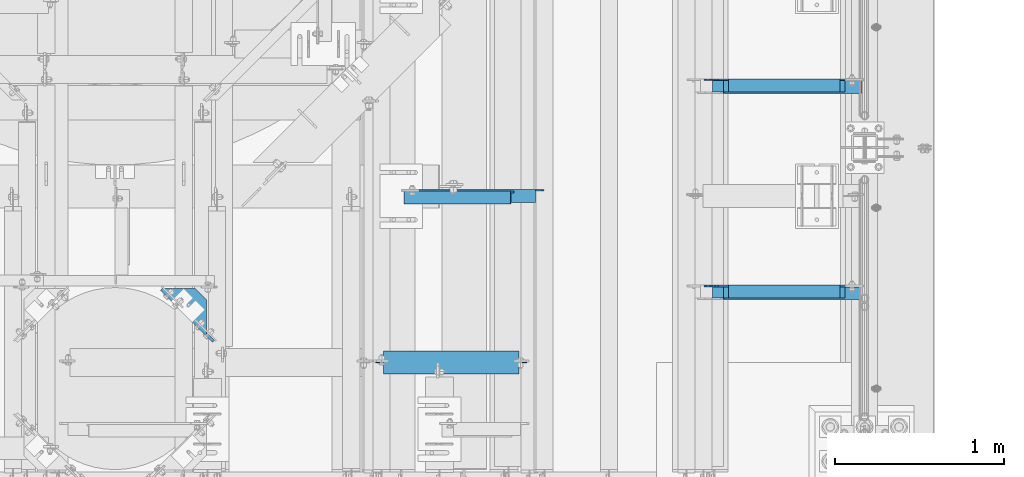
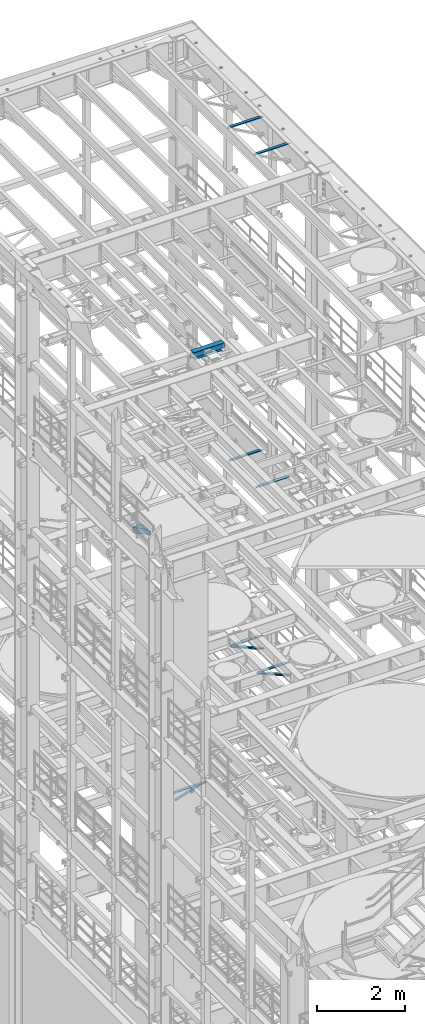
# One storey, part 1302 of 1876: 10 beams, 2 members, 12 elements without a shape of their own.
"""IFC2X3 building model written with IfcOpenShell, lengths in millimetres."""

from ifc_helpers import new_model, si_unit, frame, origin_with_axes, place, context, subcontext, project, spatial, faceted_brep, material, type_object, element, aggregate, save


model = new_model("IFC2X3")

# Units and contexts
model_context = context("Model", 3, precision=1e-05, world=origin_with_axes())
body_context = subcontext(model_context, "Body", "Model", "MODEL_VIEW")
ifc_project = project(units=[si_unit("LENGTHUNIT", "METRE", prefix="MILLI"), si_unit("AREAUNIT", "SQUARE_METRE"), si_unit("VOLUMEUNIT", "CUBIC_METRE"), si_unit("MASSUNIT", "GRAM", prefix="KILO"), si_unit("TIMEUNIT", "SECOND"), si_unit("PLANEANGLEUNIT", "RADIAN"), si_unit("SOLIDANGLEUNIT", "STERADIAN"), si_unit("THERMODYNAMICTEMPERATUREUNIT", "DEGREE_CELSIUS"), si_unit("LUMINOUSINTENSITYUNIT", "LUMEN")], contexts=[model_context])

# Site, building, storey
site_placement = place(None, origin_with_axes())
site = spatial("IfcSite", under=ifc_project, at=site_placement, CompositionType="ELEMENT")
building_placement = place(site_placement, origin_with_axes())
building = spatial("IfcBuilding", under=site, at=building_placement, Name="Undefined", CompositionType="ELEMENT")
storey_placement = place(building_placement, origin_with_axes())
storey = spatial("IfcBuildingStorey", under=building, at=storey_placement, Name="Undefined", CompositionType="ELEMENT", Elevation=0.0)

# Assembly, member
assembly_1_placement = place(storey_placement, origin_with_axes())
assembly_1 = element("IfcElementAssembly", 1, at=assembly_1_placement, inside=storey, AssemblyPlace="NOTDEFINED", PredefinedType="RIGID_FRAME")
ifc_material_1 = material(Name="STEEL/A36")
member_type = type_object("IfcMemberType", Name="L3X3X3/8", PredefinedType="NOTDEFINED")
member_1_placement = place(assembly_1_placement, frame((6716.15062848994, 8791.57499999999, 8118.31287749607), z_axis=(0.0, -1.0, 0.0), x_axis=(0.920921850882514, 0.0, -0.389747282950278)))
member_1 = element("IfcMember", 2, at=member_1_placement, type_object=member_type, material=ifc_material_1, ObjectType="L3X3X3/8", context=body_context, shape_type="Brep", body=[
    faceted_brep([(61.0981387968259, 38.0999999999804, -38.1000000000004), (61.0981387968259, 38.0999999999804, 38.1000000000004), (943.789366270678, 38.0999999998294, 38.1000000000004), (943.789366270678, 38.0999999998294, -38.1000000000004), (61.0981387968254, 28.5749999999825, 38.1000000000004), (943.789366270677, 28.5749999998316, 38.1000000000004), (61.0981387968254, 28.5749999999825, -28.5750000000007), (943.789366270677, 28.5749999998316, -28.5750000000007), (61.0981387968263, -38.1000000000022, -28.5750000000007), (943.789366270679, -38.1000000001513, -28.5750000000007), (61.0981387968263, -38.1000000000022, -38.1000000000004), (943.789366270679, -38.1000000001513, -38.1000000000004)], [[[0, 1, 2, 3]], [[1, 4, 5, 2]], [[4, 6, 7, 5]], [[6, 8, 9, 7]], [[8, 10, 11, 9]], [[10, 0, 3, 11]], [[5, 7, 9, 11, 3, 2]], [[10, 8, 6, 4, 1, 0]]]),
])
aggregate(assembly_1, [member_1])

assembly_2_placement = place(storey_placement, origin_with_axes())
assembly_2 = element("IfcElementAssembly", 3, at=assembly_2_placement, inside=storey, AssemblyPlace="NOTDEFINED", PredefinedType="RIGID_FRAME")
member_2_placement = place(assembly_2_placement, frame((6716.15062848994, 10010.775, 8118.31287749607), z_axis=(0.0, -1.0, 0.0), x_axis=(0.920921850882514, 0.0, -0.389747282950278)))
member_2 = element("IfcMember", 4, at=member_2_placement, type_object=member_type, material=ifc_material_1, ObjectType="L3X3X3/8", context=body_context, shape_type="Brep", body=[
    faceted_brep([(61.0981387968259, 38.0999999999804, -38.1000000000004), (61.0981387968259, 38.0999999999804, 38.1000000000004), (943.789366270678, 38.0999999998294, 38.1000000000004), (943.789366270678, 38.0999999998294, -38.1000000000004), (61.0981387968254, 28.5749999999825, 38.1000000000004), (943.789366270677, 28.5749999998316, 38.1000000000004), (61.0981387968254, 28.5749999999825, -28.5750000000007), (943.789366270677, 28.5749999998316, -28.5750000000007), (61.0981387968263, -38.1000000000022, -28.5750000000007), (943.789366270679, -38.1000000001513, -28.5750000000007), (61.0981387968263, -38.1000000000022, -38.1000000000004), (943.789366270679, -38.1000000001513, -38.1000000000004)], [[[0, 1, 2, 3]], [[1, 4, 5, 2]], [[4, 6, 7, 5]], [[6, 8, 9, 7]], [[8, 10, 11, 9]], [[10, 0, 3, 11]], [[5, 7, 9, 11, 3, 2]], [[10, 8, 6, 4, 1, 0]]]),
])
aggregate(assembly_2, [member_2])

# Assembly, beam
assembly_3_placement = place(storey_placement, origin_with_axes())
assembly_3 = element("IfcElementAssembly", 5, at=assembly_3_placement, inside=storey, AssemblyPlace="NOTDEFINED", PredefinedType="RIGID_FRAME")
beam_type_1 = type_object("IfcBeamType", Name="L3X3X3/8", PredefinedType="NOTDEFINED")
beam_1_placement = place(assembly_3_placement, frame((4879.97500022521, 9356.38272705379, 4870.44999999998), z_axis=(0.0, -1.0, 0.0), x_axis=(0.955933699062039, 0.0, 0.293582634019056)))
beam_1 = element("IfcBeam", 6, at=beam_1_placement, type_object=beam_type_1, material=ifc_material_1, ObjectType="L3X3X3/8", context=body_context, shape_type="Brep", body=[
    faceted_brep([(28.3079220453428, 38.1000000000076, -38.1000000000004), (28.3079220453428, 38.1000000000076, 38.1000000000004), (687.043110501988, 38.0999999999117, 38.1000000000004), (687.043110501988, 38.0999999999117, -38.1000000000004), (28.3079220453419, 28.5750000000044, 38.1000000000004), (687.043110501988, 28.5749999999093, 38.1000000000004), (28.3079220453419, 28.5750000000044, -28.5750000000007), (687.043110501988, 28.5749999999093, -28.5750000000007), (28.3079220453428, -38.1000000000158, -28.5750000000007), (687.043110501988, -38.1000000001113, -28.5750000000007), (28.3079220453428, -38.1000000000158, -38.1000000000004), (687.043110501988, -38.1000000001113, -38.1000000000004)], [[[0, 1, 2, 3]], [[1, 4, 5, 2]], [[4, 6, 7, 5]], [[6, 8, 9, 7]], [[8, 10, 11, 9]], [[10, 0, 3, 11]], [[5, 7, 9, 11, 3, 2]], [[10, 8, 6, 4, 1, 0]]]),
])
aggregate(assembly_3, [beam_1])

assembly_4_placement = place(storey_placement, origin_with_axes())
assembly_4 = element("IfcElementAssembly", 7, at=assembly_4_placement, inside=storey, Name="ANGLE", AssemblyPlace="NOTDEFINED", PredefinedType="RIGID_FRAME")
beam_2_placement = place(assembly_4_placement, frame((4879.97499990991, 9365.90772705379, 5092.7), z_axis=(0.0, -1.0, 0.0), x_axis=(1.0, 0.0, 0.0)))
beam_2 = element("IfcBeam", 8, at=beam_2_placement, type_object=beam_type_1, material=ifc_material_1, Name="ANGLE", ObjectType="L3X3X3/8", context=body_context, shape_type="Brep", body=[
    faceted_brep([(795.338000784122, 28.5749999999998, -28.5750000000007), (795.338002584359, 28.5749999999998, 38.1000000000004), (84.137014014791, 28.5749999999998, 38.1000000000258), (84.1370001605219, 28.5749999999998, -28.5750000000007), (795.338002584364, 38.1000000000004, 38.1000000000004), (84.1374011325761, 38.0999999999985, 38.0999999999776), (22.2249978717273, 28.5749999999998, -28.5750000000007), (22.2249978717273, 28.5750108587645, -38.1000000000004), (3.17499863466674, 9.52501162170302, -38.1000000000004), (3.17499863466674, 9.52501047870646, -28.5750000000007), (84.1370001605219, 28.5750108587645, -38.1000000000004), (84.137408980816, 38.0999999999985, -38.1000000000231), (795.338000527021, 38.1000000000004, -38.1000000000004), (795.338000526946, 28.5750001907354, -38.1000000000004), (831.850002775394, 28.5749999999998, -28.5750000000007), (831.850002518217, 28.5750001907354, -38.1000000000004), (844.55000258466, 15.8750003814703, -28.5750000000007), (844.550002327483, 15.8750003814703, -38.1000000000004), (844.55000258466, 3.17500152587945, -28.5750000000007), (844.550002327483, 3.17500152587945, -38.1000000000004), (844.550000160548, -38.1000000000004, -28.5750000000007), (844.550000160548, -38.1000000000004, -38.1000000000004), (3.17499999075153, -38.0999999999985, -28.5749999999998), (3.17499999075153, -38.0999999999985, -38.0999999999999), (3.17500012894925, 3.17500152587672, -38.0999999999999), (3.17500032897624, 3.17500152587672, -28.5749999999998)], [[[0, 1, 2, 3]], [[1, 4, 5, 2]], [[6, 7, 8, 9]], [[3, 10, 7, 6]], [[2, 5, 11, 10, 3]], [[4, 12, 11, 5]], [[1, 0, 13, 12, 4]], [[14, 15, 13, 0]], [[16, 17, 15, 14]], [[18, 19, 17, 16]], [[19, 18, 20, 21]], [[21, 20, 22, 23]], [[8, 7, 10, 11, 12, 13, 15, 17, 19, 21, 23, 24]], [[9, 8, 24, 25]], [[20, 18, 16, 14, 0, 3, 6, 9, 25, 22]], [[24, 23, 22, 25]]]),
])
aggregate(assembly_4, [beam_2])

assembly_5_placement = place(storey_placement, origin_with_axes())
assembly_5 = element("IfcElementAssembly", 9, at=assembly_5_placement, inside=storey, Name="ANGLE", AssemblyPlace="NOTDEFINED", PredefinedType="RIGID_FRAME")
beam_3_placement = place(assembly_5_placement, frame((6667.50000000002, 8801.1, 22517.1000001129), z_axis=(0.0, -1.0, 0.0), x_axis=(1.0, 0.0, 0.0)))
beam_3 = element("IfcBeam", 10, at=beam_3_placement, type_object=beam_type_1, material=ifc_material_1, Name="ANGLE", ObjectType="L3X3X3/8", context=body_context, shape_type="Brep", body=[
    faceted_brep([(836.613000301995, 28.5750000000007, -28.5749999999998), (836.613001168791, 28.5750000000007, 38.0999999999999), (52.3870335430847, 28.5750001907327, 38.0999999999858), (52.3869956588824, 28.5749999999955, -28.5750000000007), (836.613001168791, 38.0999999999985, 38.0999999999999), (52.387033543122, 38.0999999999985, 38.0999999999858), (15.8749936676099, 28.5749999999989, -28.5750000000007), (15.8749999382144, 28.5750001907327, -38.0999999999999), (3.17500012894925, 15.8750003814675, -38.0999999999999), (3.17500032897624, 15.8750003814675, -28.5749999999998), (52.3870393343063, 28.5750001907327, -38.1000000000149), (52.3869953826566, 38.0999999999954, -38.0999999999985), (836.613000178167, 38.0999999999985, -38.0999999999999), (836.613000301995, 12.6999991241828, -28.5749999999998), (836.613000178167, 12.6999991241828, -38.0999999999999), (913.60625591723, 12.6999991241828, -28.5749999999998), (913.606255793401, 12.6999991241828, -38.0999999999999), (945.35625591723, -19.0500008758172, -28.5749999999998), (945.356255793401, -19.0500008758172, -38.0999999999999), (945.356249999983, -38.0999999999985, -28.5749999999998), (945.356249999983, -38.0999999999985, -38.0999999999999), (3.17499999075153, -38.0999999999985, -28.5749999999998), (3.17499999075153, -38.0999999999985, -38.0999999999999), (3.17500012894925, 3.17500152587672, -38.0999999999999), (3.17500032897624, 3.17500152587672, -28.5749999999998)], [[[0, 1, 2, 3]], [[1, 4, 5, 2]], [[6, 7, 8, 9]], [[3, 10, 7, 6]], [[2, 5, 11, 10, 3]], [[4, 12, 11, 5]], [[1, 0, 13, 14, 12, 4]], [[15, 16, 14, 13]], [[16, 15, 17, 18]], [[18, 17, 19, 20]], [[20, 19, 21, 22]], [[8, 7, 10, 11, 12, 14, 16, 18, 20, 22, 23]], [[9, 8, 23, 24]], [[19, 17, 15, 13, 0, 3, 6, 9, 24, 21]], [[23, 22, 21, 24]]]),
])
aggregate(assembly_5, [beam_3])

assembly_6_placement = place(storey_placement, origin_with_axes())
assembly_6 = element("IfcElementAssembly", 11, at=assembly_6_placement, inside=storey, Name="ANGLE", AssemblyPlace="NOTDEFINED", PredefinedType="RIGID_FRAME")
beam_4_placement = place(assembly_6_placement, frame((6667.50000000002, 10020.3, 22517.1000001129), z_axis=(0.0, -1.0, 0.0), x_axis=(1.0, 0.0, 0.0)))
beam_4 = element("IfcBeam", 12, at=beam_4_placement, type_object=beam_type_1, material=ifc_material_1, Name="ANGLE", ObjectType="L3X3X3/8", context=body_context, shape_type="Brep", body=[
    faceted_brep([(836.613000301995, 28.5750000000007, -28.5749999999998), (836.613001168791, 28.5750000000007, 38.0999999999999), (52.3870335430847, 28.5750001907327, 38.0999999999858), (52.3869956588824, 28.5749999999955, -28.5750000000007), (836.613001168791, 38.0999999999985, 38.0999999999999), (52.387033543122, 38.0999999999985, 38.0999999999858), (15.8749936676099, 28.5749999999989, -28.5750000000007), (15.8749999382144, 28.5750001907327, -38.0999999999999), (3.17500012894925, 15.8750003814675, -38.0999999999999), (3.17500032897624, 15.8750003814675, -28.5749999999998), (52.3870393343063, 28.5750001907327, -38.1000000000149), (52.3869953826566, 38.0999999999954, -38.0999999999985), (836.613000178167, 38.0999999999985, -38.0999999999999), (836.613000301995, 12.6999991241828, -28.5749999999998), (836.613000178167, 12.6999991241828, -38.0999999999999), (913.60625591723, 12.6999991241828, -28.5749999999998), (913.606255793401, 12.6999991241828, -38.0999999999999), (945.35625591723, -19.0500008758172, -28.5749999999998), (945.356255793401, -19.0500008758172, -38.0999999999999), (945.356249999983, -38.0999999999985, -28.5749999999998), (945.356249999983, -38.0999999999985, -38.0999999999999), (3.17499999075153, -38.0999999999985, -28.5749999999998), (3.17499999075153, -38.0999999999985, -38.0999999999999), (3.17500012894925, 3.17500152587672, -38.0999999999999), (3.17500032897624, 3.17500152587672, -28.5749999999998)], [[[0, 1, 2, 3]], [[1, 4, 5, 2]], [[6, 7, 8, 9]], [[3, 10, 7, 6]], [[2, 5, 11, 10, 3]], [[4, 12, 11, 5]], [[1, 0, 13, 14, 12, 4]], [[15, 16, 14, 13]], [[16, 15, 17, 18]], [[18, 17, 19, 20]], [[20, 19, 21, 22]], [[8, 7, 10, 11, 12, 14, 16, 18, 20, 22, 23]], [[9, 8, 23, 24]], [[19, 17, 15, 13, 0, 3, 6, 9, 24, 21]], [[23, 22, 21, 24]]]),
])
aggregate(assembly_6, [beam_4])

assembly_7_placement = place(storey_placement, origin_with_axes())
assembly_7 = element("IfcElementAssembly", 13, at=assembly_7_placement, inside=storey, Name="ANGLE", AssemblyPlace="NOTDEFINED", PredefinedType="RIGID_FRAME")
beam_5_placement = place(assembly_7_placement, frame((6730.99999999938, 8801.1, 8115.3), z_axis=(0.0, -1.0, 0.0), x_axis=(1.0, 0.0, 0.0)))
beam_5 = element("IfcBeam", 14, at=beam_5_placement, type_object=beam_type_1, material=ifc_material_1, Name="ANGLE", ObjectType="L3X3X3/8", context=body_context, shape_type="Brep", body=[
    faceted_brep([(744.538000225918, 28.5749999999998, -28.5750000000007), (744.538000959305, 28.5749999999998, 38.1000000000004), (84.1370686928021, 28.5750001907327, 38.100000000024), (84.1370606917826, 28.5750000000007, -28.5749999999771), (744.538000959288, 38.1000000000004, 38.1000000000004), (84.1374011325761, 38.0999999999985, 38.0999999999776), (22.2249552881549, 26.9870083863452, -28.5749999999935), (22.2249551643299, 26.9870094055232, -38.0999999999931), (3.17495592726937, 7.93701016846171, -38.0999999999995), (3.17495605109434, 7.93700914928468, -28.5749999999989), (84.1369575769495, 26.9870083863452, -28.5749999999744), (84.1369574531245, 26.9870094055223, -38.099999999974), (84.137408980816, 38.0999999999985, -38.1000000000231), (744.538000121132, 38.1000000000004, -38.1000000000004), (744.538000225876, 14.2869991302496, -28.5750000000007), (744.538000121098, 14.2869991302496, -38.1000000000004), (856.456253170776, 14.2869991302496, -28.5750000000007), (856.456253065998, 14.2869991302496, -38.1000000000004), (881.856252789306, -11.1130004882807, -28.5750000000007), (881.856252684528, -11.1130004882807, -38.1000000000004), (881.856250000624, -38.1000000000004, -28.5750000000007), (881.856250000624, -38.1000000000004, -38.1000000000004), (3.17499999075153, -38.0999999999985, -28.5749999999998), (3.17499999075153, -38.0999999999985, -38.0999999999999), (3.17495592726937, 1.58700978699198, -38.0999999999995), (3.17495605109434, 1.58700876781495, -28.5749999999989)], [[[0, 1, 2, 3]], [[1, 4, 5, 2]], [[6, 7, 8, 9]], [[10, 11, 7, 6]], [[2, 5, 12, 11, 10, 3]], [[4, 13, 12, 5]], [[1, 0, 14, 15, 13, 4]], [[16, 17, 15, 14]], [[17, 16, 18, 19]], [[19, 18, 20, 21]], [[21, 20, 22, 23]], [[8, 7, 11, 12, 13, 15, 17, 19, 21, 23, 24]], [[9, 8, 24, 25]], [[20, 18, 16, 14, 0, 3, 10, 6, 9, 25, 22]], [[24, 23, 22, 25]]]),
])
aggregate(assembly_7, [beam_5])

assembly_8_placement = place(storey_placement, origin_with_axes())
assembly_8 = element("IfcElementAssembly", 15, at=assembly_8_placement, inside=storey, Name="ANGLE", AssemblyPlace="NOTDEFINED", PredefinedType="RIGID_FRAME")
beam_6_placement = place(assembly_8_placement, frame((6730.99999999938, 10020.3, 8115.3), z_axis=(0.0, -1.0, 0.0), x_axis=(1.0, 0.0, 0.0)))
beam_6 = element("IfcBeam", 16, at=beam_6_placement, type_object=beam_type_1, material=ifc_material_1, Name="ANGLE", ObjectType="L3X3X3/8", context=body_context, shape_type="Brep", body=[
    faceted_brep([(744.538000225918, 28.5749999999998, -28.5750000000007), (744.538000959305, 28.5749999999998, 38.1000000000004), (84.1370686928021, 28.5750001907327, 38.100000000024), (84.1370606917826, 28.5750000000007, -28.5749999999771), (744.538000959288, 38.1000000000004, 38.1000000000004), (84.1374011325761, 38.0999999999985, 38.0999999999776), (22.2249552881549, 26.9870083863452, -28.5749999999935), (22.2249551643299, 26.9870094055232, -38.0999999999931), (3.17495592726937, 7.93701016846171, -38.0999999999995), (3.17495605109434, 7.93700914928468, -28.5749999999989), (84.1369575769495, 26.9870083863452, -28.5749999999744), (84.1369574531245, 26.9870094055223, -38.099999999974), (84.137408980816, 38.0999999999985, -38.1000000000231), (744.538000121132, 38.1000000000004, -38.1000000000004), (744.538000225876, 14.2869991302496, -28.5750000000007), (744.538000121098, 14.2869991302496, -38.1000000000004), (856.456253170776, 14.2869991302496, -28.5750000000007), (856.456253065998, 14.2869991302496, -38.1000000000004), (881.856252789306, -11.1130004882807, -28.5750000000007), (881.856252684528, -11.1130004882807, -38.1000000000004), (881.856250000624, -38.1000000000004, -28.5750000000007), (881.856250000624, -38.1000000000004, -38.1000000000004), (3.17499999075153, -38.0999999999985, -28.5749999999998), (3.17499999075153, -38.0999999999985, -38.0999999999999), (3.17495592726937, 1.58700978699198, -38.0999999999995), (3.17495605109434, 1.58700876781495, -28.5749999999989)], [[[0, 1, 2, 3]], [[1, 4, 5, 2]], [[6, 7, 8, 9]], [[10, 11, 7, 6]], [[2, 5, 12, 11, 10, 3]], [[4, 13, 12, 5]], [[1, 0, 14, 15, 13, 4]], [[16, 17, 15, 14]], [[17, 16, 18, 19]], [[19, 18, 20, 21]], [[21, 20, 22, 23]], [[8, 7, 11, 12, 13, 15, 17, 19, 21, 23, 24]], [[9, 8, 24, 25]], [[20, 18, 16, 14, 0, 3, 10, 6, 9, 25, 22]], [[24, 23, 22, 25]]]),
])
aggregate(assembly_8, [beam_6])

assembly_9_placement = place(storey_placement, origin_with_axes())
assembly_9 = element("IfcElementAssembly", 17, at=assembly_9_placement, inside=storey, Name="ANGLE", AssemblyPlace="NOTDEFINED", PredefinedType="RIGID_FRAME")
beam_7_placement = place(assembly_9_placement, frame((6702.425, 8801.1, 13271.5), z_axis=(0.0, -1.0, 0.0), x_axis=(1.0, 0.0, 0.0)))
beam_7 = element("IfcBeam", 18, at=beam_7_placement, type_object=beam_type_1, material=ifc_material_1, Name="ANGLE", ObjectType="L3X3X3/8", context=body_context, shape_type="Brep", body=[
    faceted_brep([(801.68800030201, 28.5750000000007, -28.5750000000007), (801.688001168805, 28.5750000000007, 38.1000000000004), (84.137014014791, 28.5749999999998, 38.1000000000258), (84.1370001605219, 28.5749999999998, -28.5750000000007), (801.688001168805, 38.1000000000004, 38.1000000000004), (84.136999759924, 38.0999999999985, 38.0999999999999), (15.8750004498515, 25.4000000000005, -28.5750000000007), (15.8750002879233, 25.4000000000005, -38.1000000000004), (3.17500047865815, 12.7000001907354, -38.1000000000004), (3.1750006405864, 12.7000001907354, -28.5750000000007), (84.1369986264262, 25.4000000000005, -28.5750000000007), (84.136998464498, 25.4000000000005, -38.1000000000004), (84.1369984645207, 38.0999999999985, -38.0999999999999), (801.688000178181, 38.1000000000004, -38.1000000000004), (801.68800030201, 12.6999992370602, -28.5750000000007), (801.688000178181, 12.6999992370602, -38.1000000000004), (878.681248287849, 12.6999992370602, -28.5750000000007), (878.681248164021, 12.6999992370602, -38.1000000000004), (910.431248287849, -19.0500007629398, -28.5750000000007), (910.431248164021, -19.0500007629398, -38.1000000000004), (910.431249999999, -38.1000000000004, -28.5750000000007), (910.431249999999, -38.1000000000004, -38.1000000000004), (3.17499999075153, -38.0999999999985, -28.5749999999998), (3.17499999075153, -38.0999999999985, -38.0999999999999), (3.17500047865815, -1.52587836055318e-06, -38.1000000000004), (3.1750006405864, -1.52587836055318e-06, -28.5750000000007)], [[[0, 1, 2, 3]], [[1, 4, 5, 2]], [[6, 7, 8, 9]], [[10, 11, 7, 6]], [[2, 5, 12, 11, 10, 3]], [[4, 13, 12, 5]], [[1, 0, 14, 15, 13, 4]], [[16, 17, 15, 14]], [[17, 16, 18, 19]], [[19, 18, 20, 21]], [[21, 20, 22, 23]], [[8, 7, 11, 12, 13, 15, 17, 19, 21, 23, 24]], [[9, 8, 24, 25]], [[20, 18, 16, 14, 0, 3, 10, 6, 9, 25, 22]], [[24, 23, 22, 25]]]),
])
aggregate(assembly_9, [beam_7])

assembly_10_placement = place(storey_placement, origin_with_axes())
assembly_10 = element("IfcElementAssembly", 19, at=assembly_10_placement, inside=storey, Name="ANGLE", AssemblyPlace="NOTDEFINED", PredefinedType="RIGID_FRAME")
beam_8_placement = place(assembly_10_placement, frame((6702.425, 10020.3, 13271.5), z_axis=(0.0, -1.0, 0.0), x_axis=(1.0, 0.0, 0.0)))
beam_8 = element("IfcBeam", 20, at=beam_8_placement, type_object=beam_type_1, material=ifc_material_1, Name="ANGLE", ObjectType="L3X3X3/8", context=body_context, shape_type="Brep", body=[
    faceted_brep([(801.68800030201, 28.5750000000007, -28.5750000000007), (801.688001168805, 28.5750000000007, 38.1000000000004), (84.137014014791, 28.5749999999998, 38.1000000000258), (84.1370001605219, 28.5749999999998, -28.5750000000007), (801.688001168805, 38.1000000000004, 38.1000000000004), (84.136999759924, 38.0999999999985, 38.0999999999999), (15.8750004498515, 25.4000000000005, -28.5750000000007), (15.8750002879233, 25.4000000000005, -38.1000000000004), (3.17500047865815, 12.7000001907354, -38.1000000000004), (3.1750006405864, 12.7000001907354, -28.5750000000007), (84.1369986264262, 25.4000000000005, -28.5750000000007), (84.136998464498, 25.4000000000005, -38.1000000000004), (84.1369984645207, 38.0999999999985, -38.0999999999999), (801.688000178181, 38.1000000000004, -38.1000000000004), (801.68800030201, 12.6999992370602, -28.5750000000007), (801.688000178181, 12.6999992370602, -38.1000000000004), (878.681248287849, 12.6999992370602, -28.5750000000007), (878.681248164021, 12.6999992370602, -38.1000000000004), (910.431248287849, -19.0500007629398, -28.5750000000007), (910.431248164021, -19.0500007629398, -38.1000000000004), (910.431249999999, -38.1000000000004, -28.5750000000007), (910.431249999999, -38.1000000000004, -38.1000000000004), (3.17499999075153, -38.0999999999985, -28.5749999999998), (3.17499999075153, -38.0999999999985, -38.0999999999999), (3.17500047865815, -1.52587836055318e-06, -38.1000000000004), (3.1750006405864, -1.52587836055318e-06, -28.5750000000007)], [[[0, 1, 2, 3]], [[1, 4, 5, 2]], [[6, 7, 8, 9]], [[10, 11, 7, 6]], [[2, 5, 12, 11, 10, 3]], [[4, 13, 12, 5]], [[1, 0, 14, 15, 13, 4]], [[16, 17, 15, 14]], [[17, 16, 18, 19]], [[19, 18, 20, 21]], [[21, 20, 22, 23]], [[8, 7, 11, 12, 13, 15, 17, 19, 21, 23, 24]], [[9, 8, 24, 25]], [[20, 18, 16, 14, 0, 3, 10, 6, 9, 25, 22]], [[24, 23, 22, 25]]]),
])
aggregate(assembly_10, [beam_8])

assembly_11_placement = place(storey_placement, origin_with_axes())
assembly_11 = element("IfcElementAssembly", 21, at=assembly_11_placement, inside=storey, Name="BEAM", AssemblyPlace="NOTDEFINED", PredefinedType="RIGID_FRAME")
ifc_material_2 = material(Name="STEEL/A992")
beam_type_2 = type_object("IfcBeamType", Name="W8X18", PredefinedType="NOTDEFINED")
beam_9_placement = place(assembly_11_placement, frame((4711.7, 8382.0, 17880.0125), z_axis=(0.0, 0.0, 1.0), x_axis=(1.0, 0.0, 0.0)))
beam_9 = element("IfcBeam", 22, at=beam_9_placement, type_object=beam_type_2, material=ifc_material_2, Name="BEAM", ObjectType="W8X18", context=body_context, shape_type="Brep", body=[
    faceted_brep([(15.875, -3.17500000000018, -77.7874999999949), (15.875, 3.17500000000018, -77.7874999999949), (95.2500001907356, 3.17500000000018, -77.7874999999949), (95.2500001907356, -3.17500000000018, -77.7874999999949), (100.110079708781, 3.17500000000018, -78.7542299225825), (100.110079708781, -3.17500000000018, -78.7542299225825), (104.230256176935, 3.17500000000018, -81.50724382306), (104.230256176935, -3.17500000000018, -81.50724382306), (106.983270077413, 3.17500000000018, -85.6274202912136), (106.983270077413, -3.17500000000018, -85.6274202912136), (107.950000000001, -3.17500000000018, -90.48749980926), (107.950000000001, 3.17500000000018, -90.48749980926), (107.950000000001, 3.17500000000018, -95.25), (107.950000000001, 66.6750000000002, -95.25), (107.950000000001, 66.6750000000002, -103.1875), (107.950000000001, -66.6750000000002, -103.1875), (107.950000000001, -66.6750000000002, -95.25), (107.950000000001, -3.17500000000018, -95.25), (63.1842266547242, -66.6750000000002, 95.25), (863.915773345279, -66.6750000000002, 95.25), (863.600000000002, -66.6750000000002, 96.8374998092695), (863.600000000002, -66.6750000000002, 103.1875), (63.5000000000009, -66.6750000000002, 103.1875), (63.5000000000009, -66.6750000000002, 96.8374998092695), (863.600000000002, 66.6750000000002, 96.8374998092695), (863.600000000002, 66.6750000000002, 103.1875), (63.5000000000009, 66.6750000000002, 103.1875), (63.5000000000009, 66.6750000000002, 96.8374998092695), (863.915773345279, 66.6750000000002, 95.25), (63.1842266547242, 66.6750000000002, 95.25), (863.915773345279, 3.17500000000018, 95.25), (63.1842266547242, 3.17500000000018, 95.25), (50.8000001907358, -3.17500000000018, 84.1375000000044), (50.8000001907358, 3.17500000000018, 84.1375000000044), (15.875, 3.17500000000018, 84.1375000000044), (15.875, -3.17500000000018, 84.1375000000044), (55.6600797087813, -3.17500000000018, 85.1042299225919), (55.6600797087813, 3.17500000000018, 85.1042299225919), (59.7802561769349, -3.17500000000018, 87.8572438230694), (59.7802561769349, 3.17500000000018, 87.8572438230694), (62.5332700774129, -3.17500000000018, 91.9774202912231), (62.5332700774129, 3.17500000000018, 91.9774202912231), (63.1842266547242, -3.17500000000018, 95.25), (863.915773345279, -3.17500000000018, 95.25), (864.56672992259, -3.17500000000018, 91.9774202912231), (864.56672992259, 3.17500000000018, 91.9774202912231), (867.319743823068, -3.17500000000018, 87.8572438230694), (867.319743823068, 3.17500000000018, 87.8572438230694), (871.439920291222, -3.17500000000018, 85.1042299225919), (871.439920291222, 3.17500000000018, 85.1042299225919), (876.299999809267, -3.17500000000018, 84.1375000000044), (876.299999809267, 3.17500000000018, 84.1375000000044), (911.225000000001, -3.17500000000018, 84.1375000000044), (911.225000000001, 3.17500000000018, 84.1375000000044), (911.225000000001, -3.17500000000018, -77.7874999999949), (911.225000000001, 3.17500000000018, -77.7874999999949), (831.849999809268, -3.17500000000018, -77.7874999999949), (831.849999809268, 3.17500000000018, -77.7874999999949), (826.989920291222, -3.17500000000018, -78.7542299225825), (826.989920291222, 3.17500000000018, -78.7542299225825), (822.869743823068, -3.17500000000018, -81.50724382306), (822.869743823068, 3.17500000000018, -81.50724382306), (820.11672992259, -3.17500000000018, -85.6274202912136), (820.11672992259, 3.17500000000018, -85.6274202912136), (819.150000000002, -3.17500000000018, -90.48749980926), (819.150000000002, 3.17500000000018, -90.48749980926), (819.150000000002, -3.17500000000018, -95.25), (819.150000000002, -66.6750000000002, -95.25), (819.150000000002, -66.6750000000002, -103.1875), (819.150000000002, 66.6750000000002, -103.1875), (819.150000000002, 66.6750000000002, -95.25), (819.150000000002, 3.17500000000018, -95.25)], [[[0, 1, 2, 3]], [[3, 2, 4, 5]], [[5, 4, 6, 7]], [[7, 6, 8, 9]], [[10, 11, 12, 13, 14, 15, 16, 17]], [[9, 8, 11, 10]], [[18, 19, 20, 21, 22, 23]], [[21, 20, 24, 25]], [[21, 25, 26, 22]], [[22, 26, 27, 23]], [[25, 24, 28, 29, 27, 26]], [[28, 30, 31, 29]], [[32, 33, 34, 35]], [[36, 37, 33, 32]], [[38, 39, 37, 36]], [[40, 41, 39, 38]], [[23, 27, 29, 31, 41, 40, 42, 18]], [[43, 19, 18, 42]], [[44, 45, 30, 28, 24, 20, 19, 43]], [[46, 47, 45, 44]], [[48, 49, 47, 46]], [[50, 51, 49, 48]], [[52, 53, 51, 50]], [[53, 52, 54, 55]], [[54, 56, 57, 55]], [[58, 59, 57, 56]], [[60, 61, 59, 58]], [[62, 63, 61, 60]], [[64, 65, 63, 62]], [[66, 67, 68, 69, 70, 71, 65, 64]], [[67, 66, 17, 16]], [[68, 67, 16, 15]], [[69, 68, 15, 14]], [[70, 69, 14, 13]], [[71, 70, 13, 12]], [[6, 4, 2, 1, 34, 33, 37, 39, 41, 31, 30, 45, 47, 49, 51, 53, 55, 57, 59, 61, 63, 65, 71, 12, 11, 8]], [[35, 34, 1, 0]], [[66, 64, 62, 60, 58, 56, 54, 52, 50, 48, 46, 44, 43, 42, 40, 38, 36, 32, 35, 0, 3, 5, 7, 9, 10, 17]]]),
])
aggregate(assembly_11, [beam_9])

assembly_12_placement = place(storey_placement, origin_with_axes())
assembly_12 = element("IfcElementAssembly", 23, at=assembly_12_placement, inside=storey, Name="BEAM", AssemblyPlace="NOTDEFINED", PredefinedType="RIGID_FRAME")
beam_type_3 = type_object("IfcBeamType", Name="L6X6X5/8", PredefinedType="NOTDEFINED")
beam_10_placement = place(assembly_12_placement, frame((3486.90574079215, 8886.73153671515, 13233.4), z_axis=(0.0, 0.0, -1.0), x_axis=(0.707106781186547, -0.707106781186548, 0.0)))
beam_10 = element("IfcBeam", 24, at=beam_10_placement, type_object=beam_type_3, material=ifc_material_1, Name="BEAM", ObjectType="L6X6X5/8", context=body_context, shape_type="Brep", body=[
    faceted_brep([(421.641465885521, 76.2000000000116, -51.3447438230651), (405.766465885519, 60.3250000000098, -51.3447438230651), (401.87311629006, 60.3250000000098, -55.4649202912187), (417.748116290063, 76.2000000000116, -55.4649202912187), (427.468275326156, 76.2000000000116, -48.5917299225875), (411.593275326154, 60.325000000008, -48.5917299225875), (434.341465694791, 76.2000000000135, -47.625), (418.466465694788, 60.3250000000098, -47.625), (467.857874630892, 60.3250000000098, -47.625), (467.857983532318, 76.2000000000135, -47.625), (467.857983532318, 76.2000000000135, 76.2000000000007), (467.857874630892, 60.3250000000098, 76.2000000000007), (33.8357082546368, 76.2000000000116, 76.2000000000007), (33.8355122262315, 60.3250000000098, 76.2000000000007), (400.505953722383, 60.325000000008, -60.3250000000007), (33.8355122262315, 60.3250000000098, -60.3250000000007), (416.380953722386, 76.2000000000116, -60.3249998092651), (416.380953722386, 76.2000000000116, -76.2000000000007), (33.8357082546368, 76.2000000000116, -76.2000000000007), (170.360512226254, -76.2000000000135, -60.3250000000007), (170.360512226254, -76.2000000000135, -76.2000000000007), (263.980953722361, -76.2000000000135, -76.2000000000007), (263.980953722361, -76.2000000000135, -60.3250000000007), (33.8357202881816, 60.3247919380592, -76.2000000000007)], [[[0, 1, 2, 3]], [[4, 5, 1, 0]], [[6, 7, 5, 4]], [[8, 7, 6, 9]], [[10, 11, 8, 9]], [[11, 10, 12, 13]], [[14, 2, 1, 5, 7, 8, 11, 13, 15]], [[3, 2, 14, 16]], [[10, 9, 6, 4, 0, 3, 16, 17, 18, 12]], [[19, 20, 21, 22]], [[17, 21, 20, 23, 18]], [[16, 14, 22, 21, 17]], [[15, 19, 22, 14]], [[20, 19, 15, 23]], [[13, 12, 18, 23, 15]]]),
])
aggregate(assembly_12, [beam_10])

save(model, "model.ifc")
